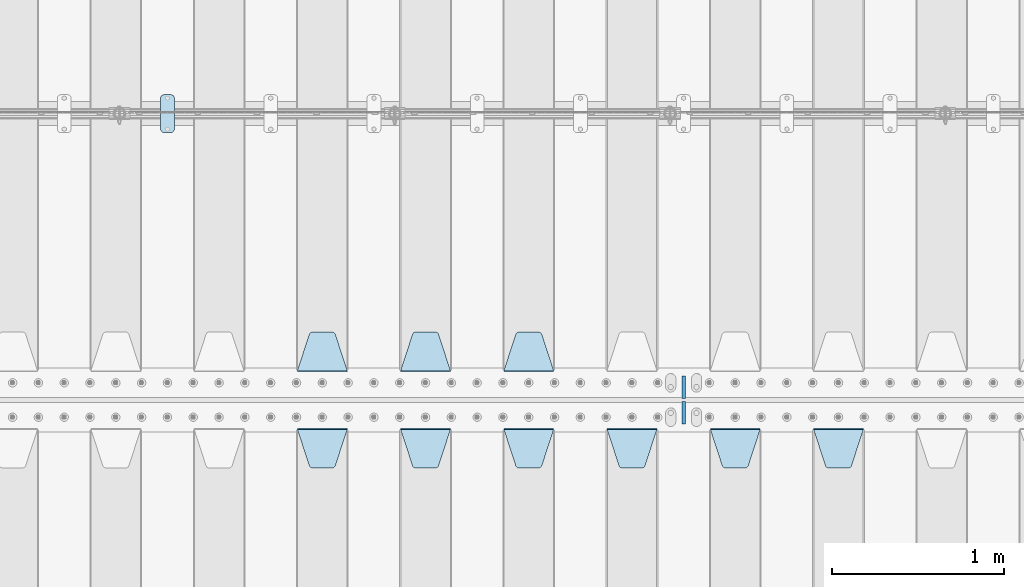
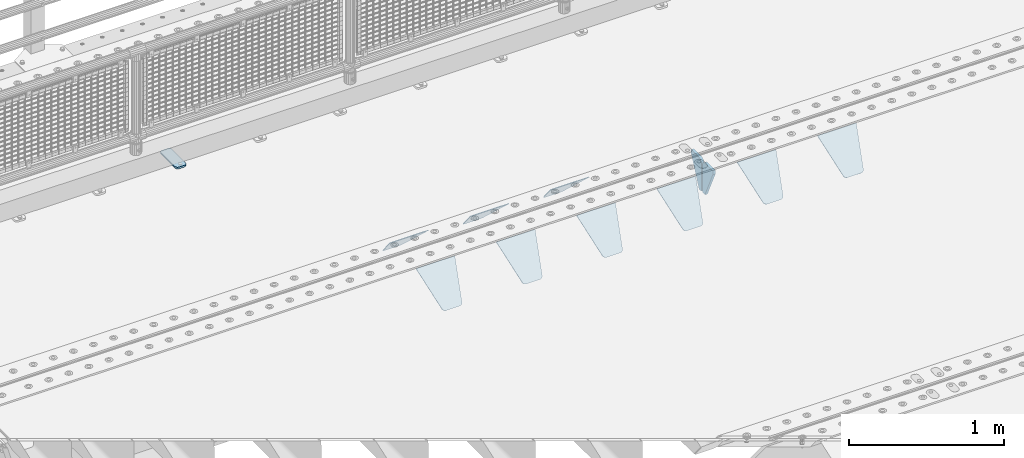
# One storey, part 219 of 257: 12 plates.
"""IFC2X3 building model written with IfcOpenShell, lengths in millimetres."""

from ifc_helpers import new_model, si_unit, frame, origin_with_axes, place, context, subcontext, project, spatial, faceted_brep, material, type_object, element, save


model = new_model("IFC2X3")

# Units and contexts
model_context = context("Model", 3, precision=1e-05, world=origin_with_axes())
body_context = subcontext(model_context, "Body", "Model", "MODEL_VIEW")
ifc_project = project(units=[si_unit("LENGTHUNIT", "METRE", prefix="MILLI"), si_unit("AREAUNIT", "SQUARE_METRE"), si_unit("VOLUMEUNIT", "CUBIC_METRE"), si_unit("MASSUNIT", "GRAM", prefix="KILO"), si_unit("TIMEUNIT", "SECOND"), si_unit("PLANEANGLEUNIT", "RADIAN"), si_unit("SOLIDANGLEUNIT", "STERADIAN"), si_unit("THERMODYNAMICTEMPERATUREUNIT", "DEGREE_CELSIUS"), si_unit("LUMINOUSINTENSITYUNIT", "LUMEN")], contexts=[model_context])

# Site, building, storey
site_placement = place(None, origin_with_axes())
site = spatial("IfcSite", under=ifc_project, at=site_placement, CompositionType="ELEMENT")
building_placement = place(site_placement, origin_with_axes())
building = spatial("IfcBuilding", under=site, at=building_placement, Name="Standard", CompositionType="ELEMENT")
storey_placement = place(building_placement, origin_with_axes())
storey = spatial("IfcBuildingStorey", under=building, at=storey_placement, Name="Undefined", CompositionType="ELEMENT", Elevation=0.0)

# Plates
ifc_material_1 = material(Name="STEEL/S355J2")
plate_type_1 = type_object("IfcPlateType", PredefinedType="NOTDEFINED")
plate_1_placement = place(storey_placement, frame((44910.0, 10774.5, 21.0199999999977), z_axis=(1.0, 0.0, 0.0), x_axis=(0.0, -1.0, 0.0)))
element("IfcPlate", 1, at=plate_1_placement, inside=storey, type_object=plate_type_1, material=ifc_material_1, context=body_context, shape_type="Brep", body=[
    faceted_brep([(0.0, -7.0, 20.0), (0.0, -7.0, 60.0), (0.0, 7.0, 60.0), (0.0, 7.0, 20.0), (0.384294391935327, -7.0, 63.9018064403208), (0.384294391935327, 7.0, 63.9018064403208), (1.52240934977453, -7.0, 67.6536686473046), (1.52240934977453, 7.0, 67.6536686473046), (3.37060775394821, -7.0, 71.1114046603907), (3.37060775394821, 7.0, 71.1114046603907), (5.85786437626848, -7.0, 74.1421356237333), (5.85786437626848, 7.0, 74.1421356237333), (8.88859533960749, -7.0, 76.6293922460536), (8.88859533960749, 7.0, 76.6293922460536), (12.3463313526991, -7.0, 78.4775906502255), (12.3463313526991, 7.0, 78.4775906502255), (16.0981935596774, -7.0, 79.6157056080629), (16.0981935596774, 7.0, 79.6157056080629), (20.0, -7.0, 80.0), (20.0, 7.0, 80.0), (200.0, -7.0, 80.0), (200.0, 7.0, 80.0), (203.901806440323, -7.0, 79.6157056080629), (203.901806440323, 7.0, 79.6157056080629), (207.653668647301, -7.0, 78.4775906502255), (207.653668647301, 7.0, 78.4775906502255), (211.111404660393, -7.0, 76.6293922460536), (211.111404660393, 7.0, 76.6293922460536), (214.142135623732, -7.0, 74.1421356237333), (214.142135623732, 7.0, 74.1421356237333), (216.629392246052, -7.0, 71.1114046603907), (216.629392246052, 7.0, 71.1114046603907), (218.477590650225, -7.0, 67.6536686473046), (218.477590650225, 7.0, 67.6536686473046), (219.615705608065, -7.0, 63.9018064403208), (219.615705608065, 7.0, 63.9018064403208), (220.0, -7.0, 60.0), (220.0, 7.0, 60.0), (220.0, -7.0, 20.0), (220.0, 7.0, 20.0), (219.615705608065, -7.0, 16.0981935596792), (219.615705608065, 7.0, 16.0981935596792), (218.477590650225, -7.0, 12.3463313526954), (218.477590650225, 7.0, 12.3463313526954), (216.629392246052, -7.0, 8.88859533960931), (216.629392246052, 7.0, 8.88859533960931), (214.142135623732, -7.0, 5.85786437626666), (214.142135623732, 7.0, 5.85786437626666), (211.111404660393, -7.0, 3.37060775394639), (211.111404660393, 7.0, 3.37060775394639), (207.653668647301, -7.0, 1.52240934977453), (207.653668647301, 7.0, 1.52240934977453), (203.901806440323, -7.0, 0.384294391937146), (203.901806440323, 7.0, 0.384294391937146), (200.0, -7.0, 0.0), (200.0, 7.0, 0.0), (20.0, -7.0, 0.0), (20.0, 7.0, 0.0), (16.0981935596774, -7.0, 0.384294391937146), (16.0981935596774, 7.0, 0.384294391937146), (12.3463313526991, -7.0, 1.52240934977453), (12.3463313526991, 7.0, 1.52240934977453), (8.88859533960749, -7.0, 3.37060775394639), (8.88859533960749, 7.0, 3.37060775394639), (5.85786437626848, -7.0, 5.85786437626666), (5.85786437626848, 7.0, 5.85786437626666), (3.37060775394821, -7.0, 8.88859533960931), (3.37060775394821, 7.0, 8.88859533960931), (1.52240934977453, -7.0, 12.3463313526954), (1.52240934977453, 7.0, 12.3463313526954), (0.384294391935327, -7.0, 16.0981935596792), (0.384294391935327, 7.0, 16.0981935596792)], [[[0, 1, 2, 3]], [[1, 4, 5, 2]], [[4, 6, 7, 5]], [[6, 8, 9, 7]], [[8, 10, 11, 9]], [[10, 12, 13, 11]], [[12, 14, 15, 13]], [[14, 16, 17, 15]], [[16, 18, 19, 17]], [[18, 20, 21, 19]], [[20, 22, 23, 21]], [[22, 24, 25, 23]], [[24, 26, 27, 25]], [[26, 28, 29, 27]], [[28, 30, 31, 29]], [[30, 32, 33, 31]], [[32, 34, 35, 33]], [[34, 36, 37, 35]], [[36, 38, 39, 37]], [[38, 40, 41, 39]], [[40, 42, 43, 41]], [[42, 44, 45, 43]], [[44, 46, 47, 45]], [[46, 48, 49, 47]], [[48, 50, 51, 49]], [[50, 52, 53, 51]], [[52, 54, 55, 53]], [[54, 56, 57, 55]], [[56, 58, 59, 57]], [[58, 60, 61, 59]], [[60, 62, 63, 61]], [[62, 64, 65, 63]], [[64, 66, 67, 65]], [[66, 68, 69, 67]], [[68, 70, 71, 69]], [[70, 0, 3, 71]], [[5, 7, 9, 11, 13, 15, 17, 19, 21, 23, 25, 27, 29, 31, 33, 35, 37, 39, 41, 43, 45, 47, 49, 51, 53, 55, 57, 59, 61, 63, 65, 67, 69, 71, 3, 2]], [[70, 68, 66, 64, 62, 60, 58, 56, 54, 52, 50, 48, 46, 44, 42, 40, 38, 36, 34, 32, 30, 28, 26, 24, 22, 20, 18, 16, 14, 12, 10, 8, 6, 4, 1, 0]]]),
])
ifc_material_2 = material(Name="STEEL/S355N")
plate_type_2 = type_object("IfcPlateType", PredefinedType="NOTDEFINED")
plate_2_placement = place(storey_placement, frame((48705.0, 8831.76776695594, -1.767766952965), z_axis=(0.0, -0.707106781186548, -0.707106781186547), x_axis=(1.0, 0.0, 0.0)))
element("IfcPlate", 2, at=plate_2_placement, inside=storey, type_object=plate_type_2, material=ifc_material_2, context=body_context, shape_type="Brep", body=[
    faceted_brep([(0.0, -2.5, 0.0), (69.345504679477, -2.50000000000091, 300.17173142483), (69.345504679477, 2.5, 300.171731424831), (0.0, 2.5, 0.0), (70.927406119954, -2.50000000000091, 304.8974424154), (70.927406119954, 2.5, 304.8974424154), (73.3818627772271, -2.50000000000091, 309.234538108527), (73.3818627772271, 2.49999999999909, 309.234538108527), (76.6187032999587, -2.5, 313.023683126103), (76.6187032999587, 2.5, 313.023683126103), (80.5190132705029, -2.5, 316.125672595372), (80.5190132705029, 2.5, 316.125672595371), (84.9395038596849, -2.5, 318.426546230476), (84.9395038596849, 2.5, 318.426546230477), (89.7177759439219, -2.5, 319.841774983275), (89.7177759439219, 2.5, 319.841774983275), (94.6782862926484, -2.5, 320.319366455079), (94.6782862926484, 2.5, 320.319366455079), (195.321713707352, -2.5, 320.319366455079), (195.321713707352, 2.5, 320.319366455079), (200.282224056078, -2.5, 319.841774983275), (200.282224056078, 2.49999999999909, 319.841774983275), (205.060496140315, -2.5, 318.426546230476), (205.060496140315, 2.49999999999909, 318.426546230475), (209.480986729497, -2.5, 316.125672595371), (209.480986729497, 2.5, 316.125672595371), (213.381296700041, -2.50000000000091, 313.023683126102), (213.381296700041, 2.5, 313.023683126103), (216.618137222766, -2.50000000000091, 309.234538108527), (216.618137222766, 2.5, 309.234538108527), (219.072593880039, -2.5, 304.897442415399), (219.072593880039, 2.5, 304.897442415399), (220.654495320523, -2.50000000000091, 300.17173142483), (220.654495320523, 2.5, 300.171731424831), (290.0, -2.50000000000091, 0.0), (290.0, 2.5, 9.09494701772928e-13)], [[[0, 1, 2, 3]], [[1, 4, 5, 2]], [[4, 6, 7, 5]], [[6, 8, 9, 7]], [[8, 10, 11, 9]], [[10, 12, 13, 11]], [[12, 14, 15, 13]], [[14, 16, 17, 15]], [[16, 18, 19, 17]], [[18, 20, 21, 19]], [[20, 22, 23, 21]], [[22, 24, 25, 23]], [[24, 26, 27, 25]], [[26, 28, 29, 27]], [[28, 30, 31, 29]], [[30, 32, 33, 31]], [[32, 34, 35, 33]], [[34, 0, 3, 35]], [[5, 7, 9, 11, 13, 15, 17, 19, 21, 23, 25, 27, 29, 31, 33, 35, 3, 2]], [[34, 32, 30, 28, 26, 24, 22, 20, 18, 16, 14, 12, 10, 8, 6, 4, 1, 0]]]),
])
plate_3_placement = place(storey_placement, frame((48105.0, 8831.76776695594, -1.767766952965), z_axis=(0.0, -0.707106781186548, -0.707106781186547), x_axis=(1.0, 0.0, 0.0)))
element("IfcPlate", 3, at=plate_3_placement, inside=storey, type_object=plate_type_2, material=ifc_material_2, context=body_context, shape_type="Brep", body=[
    faceted_brep([(0.0, -2.5, 0.0), (69.345504679477, -2.50000000000091, 300.17173142483), (69.345504679477, 2.5, 300.171731424831), (0.0, 2.5, 0.0), (70.927406119954, -2.50000000000091, 304.8974424154), (70.927406119954, 2.5, 304.8974424154), (73.3818627772271, -2.50000000000091, 309.234538108527), (73.3818627772271, 2.49999999999909, 309.234538108527), (76.6187032999587, -2.5, 313.023683126103), (76.6187032999587, 2.5, 313.023683126103), (80.5190132705029, -2.5, 316.125672595372), (80.5190132705029, 2.5, 316.125672595371), (84.9395038596849, -2.5, 318.426546230476), (84.9395038596849, 2.5, 318.426546230477), (89.7177759439219, -2.5, 319.841774983275), (89.7177759439219, 2.5, 319.841774983275), (94.6782862926484, -2.5, 320.319366455079), (94.6782862926484, 2.5, 320.319366455079), (195.321713707352, -2.5, 320.319366455079), (195.321713707352, 2.5, 320.319366455079), (200.282224056078, -2.5, 319.841774983275), (200.282224056078, 2.49999999999909, 319.841774983275), (205.060496140315, -2.5, 318.426546230476), (205.060496140315, 2.49999999999909, 318.426546230475), (209.480986729497, -2.5, 316.125672595371), (209.480986729497, 2.5, 316.125672595371), (213.381296700041, -2.50000000000091, 313.023683126102), (213.381296700041, 2.5, 313.023683126103), (216.618137222766, -2.50000000000091, 309.234538108527), (216.618137222766, 2.5, 309.234538108527), (219.072593880039, -2.5, 304.897442415399), (219.072593880039, 2.5, 304.897442415399), (220.654495320523, -2.50000000000091, 300.17173142483), (220.654495320523, 2.5, 300.171731424831), (290.0, -2.50000000000091, 0.0), (290.0, 2.5, 9.09494701772928e-13)], [[[0, 1, 2, 3]], [[1, 4, 5, 2]], [[4, 6, 7, 5]], [[6, 8, 9, 7]], [[8, 10, 11, 9]], [[10, 12, 13, 11]], [[12, 14, 15, 13]], [[14, 16, 17, 15]], [[16, 18, 19, 17]], [[18, 20, 21, 19]], [[20, 22, 23, 21]], [[22, 24, 25, 23]], [[24, 26, 27, 25]], [[26, 28, 29, 27]], [[28, 30, 31, 29]], [[30, 32, 33, 31]], [[32, 34, 35, 33]], [[34, 0, 3, 35]], [[5, 7, 9, 11, 13, 15, 17, 19, 21, 23, 25, 27, 29, 31, 33, 35, 3, 2]], [[34, 32, 30, 28, 26, 24, 22, 20, 18, 16, 14, 12, 10, 8, 6, 4, 1, 0]]]),
])
plate_4_placement = place(storey_placement, frame((47505.0, 8831.76776695594, -1.767766952965), z_axis=(0.0, -0.707106781186548, -0.707106781186547), x_axis=(1.0, 0.0, 0.0)))
element("IfcPlate", 4, at=plate_4_placement, inside=storey, type_object=plate_type_2, material=ifc_material_2, context=body_context, shape_type="Brep", body=[
    faceted_brep([(0.0, -2.5, 0.0), (69.345504679477, -2.50000000000091, 300.17173142483), (69.345504679477, 2.5, 300.171731424831), (0.0, 2.5, 0.0), (70.927406119954, -2.50000000000091, 304.8974424154), (70.927406119954, 2.5, 304.8974424154), (73.3818627772271, -2.50000000000091, 309.234538108527), (73.3818627772271, 2.49999999999909, 309.234538108527), (76.6187032999587, -2.5, 313.023683126103), (76.6187032999587, 2.5, 313.023683126103), (80.5190132705029, -2.5, 316.125672595372), (80.5190132705029, 2.5, 316.125672595371), (84.9395038596849, -2.5, 318.426546230476), (84.9395038596849, 2.5, 318.426546230477), (89.7177759439219, -2.5, 319.841774983275), (89.7177759439219, 2.5, 319.841774983275), (94.6782862926484, -2.5, 320.319366455079), (94.6782862926484, 2.5, 320.319366455079), (195.321713707352, -2.5, 320.319366455079), (195.321713707352, 2.5, 320.319366455079), (200.282224056078, -2.5, 319.841774983275), (200.282224056078, 2.49999999999909, 319.841774983275), (205.060496140315, -2.5, 318.426546230476), (205.060496140315, 2.49999999999909, 318.426546230475), (209.480986729497, -2.5, 316.125672595371), (209.480986729497, 2.5, 316.125672595371), (213.381296700041, -2.50000000000091, 313.023683126102), (213.381296700041, 2.5, 313.023683126103), (216.618137222766, -2.50000000000091, 309.234538108527), (216.618137222766, 2.5, 309.234538108527), (219.072593880039, -2.5, 304.897442415399), (219.072593880039, 2.5, 304.897442415399), (220.654495320523, -2.50000000000091, 300.17173142483), (220.654495320523, 2.5, 300.171731424831), (290.0, -2.50000000000091, 0.0), (290.0, 2.5, 9.09494701772928e-13)], [[[0, 1, 2, 3]], [[1, 4, 5, 2]], [[4, 6, 7, 5]], [[6, 8, 9, 7]], [[8, 10, 11, 9]], [[10, 12, 13, 11]], [[12, 14, 15, 13]], [[14, 16, 17, 15]], [[16, 18, 19, 17]], [[18, 20, 21, 19]], [[20, 22, 23, 21]], [[22, 24, 25, 23]], [[24, 26, 27, 25]], [[26, 28, 29, 27]], [[28, 30, 31, 29]], [[30, 32, 33, 31]], [[32, 34, 35, 33]], [[34, 0, 3, 35]], [[5, 7, 9, 11, 13, 15, 17, 19, 21, 23, 25, 27, 29, 31, 33, 35, 3, 2]], [[34, 32, 30, 28, 26, 24, 22, 20, 18, 16, 14, 12, 10, 8, 6, 4, 1, 0]]]),
])
plate_5_placement = place(storey_placement, frame((46905.0, 8831.76776695594, -1.767766952965), z_axis=(0.0, -0.707106781186548, -0.707106781186547), x_axis=(1.0, 0.0, 0.0)))
element("IfcPlate", 5, at=plate_5_placement, inside=storey, type_object=plate_type_2, material=ifc_material_2, context=body_context, shape_type="Brep", body=[
    faceted_brep([(0.0, -2.5, 0.0), (69.345504679477, -2.50000000000091, 300.17173142483), (69.345504679477, 2.5, 300.171731424831), (0.0, 2.5, 0.0), (70.927406119954, -2.50000000000091, 304.8974424154), (70.927406119954, 2.5, 304.8974424154), (73.3818627772271, -2.50000000000091, 309.234538108527), (73.3818627772271, 2.49999999999909, 309.234538108527), (76.6187032999587, -2.5, 313.023683126103), (76.6187032999587, 2.5, 313.023683126103), (80.5190132705029, -2.5, 316.125672595372), (80.5190132705029, 2.5, 316.125672595371), (84.9395038596849, -2.5, 318.426546230476), (84.9395038596849, 2.5, 318.426546230477), (89.7177759439219, -2.5, 319.841774983275), (89.7177759439219, 2.5, 319.841774983275), (94.6782862926484, -2.5, 320.319366455079), (94.6782862926484, 2.5, 320.319366455079), (195.321713707352, -2.5, 320.319366455079), (195.321713707352, 2.5, 320.319366455079), (200.282224056078, -2.5, 319.841774983275), (200.282224056078, 2.49999999999909, 319.841774983275), (205.060496140315, -2.5, 318.426546230476), (205.060496140315, 2.49999999999909, 318.426546230475), (209.480986729497, -2.5, 316.125672595371), (209.480986729497, 2.5, 316.125672595371), (213.381296700041, -2.50000000000091, 313.023683126102), (213.381296700041, 2.5, 313.023683126103), (216.618137222766, -2.50000000000091, 309.234538108527), (216.618137222766, 2.5, 309.234538108527), (219.072593880039, -2.5, 304.897442415399), (219.072593880039, 2.5, 304.897442415399), (220.654495320523, -2.50000000000091, 300.17173142483), (220.654495320523, 2.5, 300.171731424831), (290.0, -2.50000000000091, 0.0), (290.0, 2.5, 9.09494701772928e-13)], [[[0, 1, 2, 3]], [[1, 4, 5, 2]], [[4, 6, 7, 5]], [[6, 8, 9, 7]], [[8, 10, 11, 9]], [[10, 12, 13, 11]], [[12, 14, 15, 13]], [[14, 16, 17, 15]], [[16, 18, 19, 17]], [[18, 20, 21, 19]], [[20, 22, 23, 21]], [[22, 24, 25, 23]], [[24, 26, 27, 25]], [[26, 28, 29, 27]], [[28, 30, 31, 29]], [[30, 32, 33, 31]], [[32, 34, 35, 33]], [[34, 0, 3, 35]], [[5, 7, 9, 11, 13, 15, 17, 19, 21, 23, 25, 27, 29, 31, 33, 35, 3, 2]], [[34, 32, 30, 28, 26, 24, 22, 20, 18, 16, 14, 12, 10, 8, 6, 4, 1, 0]]]),
])
plate_6_placement = place(storey_placement, frame((46305.0, 8831.76776695594, -1.767766952965), z_axis=(0.0, -0.707106781186548, -0.707106781186547), x_axis=(1.0, 0.0, 0.0)))
element("IfcPlate", 6, at=plate_6_placement, inside=storey, type_object=plate_type_2, material=ifc_material_2, context=body_context, shape_type="Brep", body=[
    faceted_brep([(0.0, -2.5, 0.0), (69.345504679477, -2.50000000000091, 300.17173142483), (69.345504679477, 2.5, 300.171731424831), (0.0, 2.5, 0.0), (70.927406119954, -2.50000000000091, 304.8974424154), (70.927406119954, 2.5, 304.8974424154), (73.3818627772271, -2.50000000000091, 309.234538108527), (73.3818627772271, 2.49999999999909, 309.234538108527), (76.6187032999587, -2.5, 313.023683126103), (76.6187032999587, 2.5, 313.023683126103), (80.5190132705029, -2.5, 316.125672595372), (80.5190132705029, 2.5, 316.125672595371), (84.9395038596849, -2.5, 318.426546230476), (84.9395038596849, 2.5, 318.426546230477), (89.7177759439219, -2.5, 319.841774983275), (89.7177759439219, 2.5, 319.841774983275), (94.6782862926484, -2.5, 320.319366455079), (94.6782862926484, 2.5, 320.319366455079), (195.321713707352, -2.5, 320.319366455079), (195.321713707352, 2.5, 320.319366455079), (200.282224056078, -2.5, 319.841774983275), (200.282224056078, 2.49999999999909, 319.841774983275), (205.060496140315, -2.5, 318.426546230476), (205.060496140315, 2.49999999999909, 318.426546230475), (209.480986729497, -2.5, 316.125672595371), (209.480986729497, 2.5, 316.125672595371), (213.381296700041, -2.50000000000091, 313.023683126102), (213.381296700041, 2.5, 313.023683126103), (216.618137222766, -2.50000000000091, 309.234538108527), (216.618137222766, 2.5, 309.234538108527), (219.072593880039, -2.5, 304.897442415399), (219.072593880039, 2.5, 304.897442415399), (220.654495320523, -2.50000000000091, 300.17173142483), (220.654495320523, 2.5, 300.171731424831), (290.0, -2.50000000000091, 0.0), (290.0, 2.5, 9.09494701772928e-13)], [[[0, 1, 2, 3]], [[1, 4, 5, 2]], [[4, 6, 7, 5]], [[6, 8, 9, 7]], [[8, 10, 11, 9]], [[10, 12, 13, 11]], [[12, 14, 15, 13]], [[14, 16, 17, 15]], [[16, 18, 19, 17]], [[18, 20, 21, 19]], [[20, 22, 23, 21]], [[22, 24, 25, 23]], [[24, 26, 27, 25]], [[26, 28, 29, 27]], [[28, 30, 31, 29]], [[30, 32, 33, 31]], [[32, 34, 35, 33]], [[34, 0, 3, 35]], [[5, 7, 9, 11, 13, 15, 17, 19, 21, 23, 25, 27, 29, 31, 33, 35, 3, 2]], [[34, 32, 30, 28, 26, 24, 22, 20, 18, 16, 14, 12, 10, 8, 6, 4, 1, 0]]]),
])
plate_7_placement = place(storey_placement, frame((45705.0, 8831.76776695594, -1.767766952965), z_axis=(0.0, -0.707106781186548, -0.707106781186547), x_axis=(1.0, 0.0, 0.0)))
element("IfcPlate", 7, at=plate_7_placement, inside=storey, type_object=plate_type_2, material=ifc_material_2, context=body_context, shape_type="Brep", body=[
    faceted_brep([(0.0, -2.5, 0.0), (69.345504679477, -2.50000000000091, 300.17173142483), (69.345504679477, 2.5, 300.171731424831), (0.0, 2.5, 0.0), (70.927406119954, -2.50000000000091, 304.8974424154), (70.927406119954, 2.5, 304.8974424154), (73.3818627772271, -2.50000000000091, 309.234538108527), (73.3818627772271, 2.49999999999909, 309.234538108527), (76.6187032999587, -2.5, 313.023683126103), (76.6187032999587, 2.5, 313.023683126103), (80.5190132705029, -2.5, 316.125672595372), (80.5190132705029, 2.5, 316.125672595371), (84.9395038596849, -2.5, 318.426546230476), (84.9395038596849, 2.5, 318.426546230477), (89.7177759439219, -2.5, 319.841774983275), (89.7177759439219, 2.5, 319.841774983275), (94.6782862926484, -2.5, 320.319366455079), (94.6782862926484, 2.5, 320.319366455079), (195.321713707352, -2.5, 320.319366455079), (195.321713707352, 2.5, 320.319366455079), (200.282224056078, -2.5, 319.841774983275), (200.282224056078, 2.49999999999909, 319.841774983275), (205.060496140315, -2.5, 318.426546230476), (205.060496140315, 2.49999999999909, 318.426546230475), (209.480986729497, -2.5, 316.125672595371), (209.480986729497, 2.5, 316.125672595371), (213.381296700041, -2.50000000000091, 313.023683126102), (213.381296700041, 2.5, 313.023683126103), (216.618137222766, -2.50000000000091, 309.234538108527), (216.618137222766, 2.5, 309.234538108527), (219.072593880039, -2.5, 304.897442415399), (219.072593880039, 2.5, 304.897442415399), (220.654495320523, -2.50000000000091, 300.17173142483), (220.654495320523, 2.5, 300.171731424831), (290.0, -2.50000000000091, 0.0), (290.0, 2.5, 9.09494701772928e-13)], [[[0, 1, 2, 3]], [[1, 4, 5, 2]], [[4, 6, 7, 5]], [[6, 8, 9, 7]], [[8, 10, 11, 9]], [[10, 12, 13, 11]], [[12, 14, 15, 13]], [[14, 16, 17, 15]], [[16, 18, 19, 17]], [[18, 20, 21, 19]], [[20, 22, 23, 21]], [[22, 24, 25, 23]], [[24, 26, 27, 25]], [[26, 28, 29, 27]], [[28, 30, 31, 29]], [[30, 32, 33, 31]], [[32, 34, 35, 33]], [[34, 0, 3, 35]], [[5, 7, 9, 11, 13, 15, 17, 19, 21, 23, 25, 27, 29, 31, 33, 35, 3, 2]], [[34, 32, 30, 28, 26, 24, 22, 20, 18, 16, 14, 12, 10, 8, 6, 4, 1, 0]]]),
])
plate_8_placement = place(storey_placement, frame((47195.0, 9168.23223304703, -1.76776695296758), z_axis=(0.0, 0.707106781186547, -0.707106781186548), x_axis=(-1.0, 0.0, 0.0)))
element("IfcPlate", 8, at=plate_8_placement, inside=storey, type_object=plate_type_2, material=ifc_material_2, context=body_context, shape_type="Brep", body=[
    faceted_brep([(0.0, -2.5, 0.0), (69.345504679477, -2.50000000000091, 300.17173142483), (69.345504679477, 2.5, 300.171731424831), (0.0, 2.5, 0.0), (70.927406119954, -2.50000000000091, 304.8974424154), (70.927406119954, 2.5, 304.8974424154), (73.3818627772271, -2.50000000000091, 309.234538108527), (73.3818627772271, 2.49999999999909, 309.234538108527), (76.6187032999587, -2.5, 313.023683126103), (76.6187032999587, 2.5, 313.023683126103), (80.5190132705029, -2.5, 316.125672595372), (80.5190132705029, 2.5, 316.125672595371), (84.9395038596849, -2.5, 318.426546230476), (84.9395038596849, 2.5, 318.426546230477), (89.7177759439219, -2.5, 319.841774983275), (89.7177759439219, 2.5, 319.841774983275), (94.6782862926484, -2.5, 320.319366455079), (94.6782862926484, 2.5, 320.319366455079), (195.321713707352, -2.5, 320.319366455079), (195.321713707352, 2.5, 320.319366455079), (200.282224056078, -2.5, 319.841774983275), (200.282224056078, 2.49999999999909, 319.841774983275), (205.060496140315, -2.5, 318.426546230476), (205.060496140315, 2.49999999999909, 318.426546230475), (209.480986729497, -2.5, 316.125672595371), (209.480986729497, 2.5, 316.125672595371), (213.381296700041, -2.50000000000091, 313.023683126102), (213.381296700041, 2.5, 313.023683126103), (216.618137222766, -2.50000000000091, 309.234538108527), (216.618137222766, 2.5, 309.234538108527), (219.072593880039, -2.5, 304.897442415399), (219.072593880039, 2.5, 304.897442415399), (220.654495320523, -2.50000000000091, 300.17173142483), (220.654495320523, 2.5, 300.171731424831), (290.0, -2.50000000000091, 0.0), (290.0, 2.5, 9.09494701772928e-13)], [[[0, 1, 2, 3]], [[1, 4, 5, 2]], [[4, 6, 7, 5]], [[6, 8, 9, 7]], [[8, 10, 11, 9]], [[10, 12, 13, 11]], [[12, 14, 15, 13]], [[14, 16, 17, 15]], [[16, 18, 19, 17]], [[18, 20, 21, 19]], [[20, 22, 23, 21]], [[22, 24, 25, 23]], [[24, 26, 27, 25]], [[26, 28, 29, 27]], [[28, 30, 31, 29]], [[30, 32, 33, 31]], [[32, 34, 35, 33]], [[34, 0, 3, 35]], [[5, 7, 9, 11, 13, 15, 17, 19, 21, 23, 25, 27, 29, 31, 33, 35, 3, 2]], [[34, 32, 30, 28, 26, 24, 22, 20, 18, 16, 14, 12, 10, 8, 6, 4, 1, 0]]]),
])
plate_9_placement = place(storey_placement, frame((46595.0, 9168.23223304703, -1.76776695296758), z_axis=(0.0, 0.707106781186547, -0.707106781186548), x_axis=(-1.0, 0.0, 0.0)))
element("IfcPlate", 9, at=plate_9_placement, inside=storey, type_object=plate_type_2, material=ifc_material_2, context=body_context, shape_type="Brep", body=[
    faceted_brep([(0.0, -2.5, 0.0), (69.345504679477, -2.50000000000091, 300.17173142483), (69.345504679477, 2.5, 300.171731424831), (0.0, 2.5, 0.0), (70.927406119954, -2.50000000000091, 304.8974424154), (70.927406119954, 2.5, 304.8974424154), (73.3818627772271, -2.50000000000091, 309.234538108527), (73.3818627772271, 2.49999999999909, 309.234538108527), (76.6187032999587, -2.5, 313.023683126103), (76.6187032999587, 2.5, 313.023683126103), (80.5190132705029, -2.5, 316.125672595372), (80.5190132705029, 2.5, 316.125672595371), (84.9395038596849, -2.5, 318.426546230476), (84.9395038596849, 2.5, 318.426546230477), (89.7177759439219, -2.5, 319.841774983275), (89.7177759439219, 2.5, 319.841774983275), (94.6782862926484, -2.5, 320.319366455079), (94.6782862926484, 2.5, 320.319366455079), (195.321713707352, -2.5, 320.319366455079), (195.321713707352, 2.5, 320.319366455079), (200.282224056078, -2.5, 319.841774983275), (200.282224056078, 2.49999999999909, 319.841774983275), (205.060496140315, -2.5, 318.426546230476), (205.060496140315, 2.49999999999909, 318.426546230475), (209.480986729497, -2.5, 316.125672595371), (209.480986729497, 2.5, 316.125672595371), (213.381296700041, -2.50000000000091, 313.023683126102), (213.381296700041, 2.5, 313.023683126103), (216.618137222766, -2.50000000000091, 309.234538108527), (216.618137222766, 2.5, 309.234538108527), (219.072593880039, -2.5, 304.897442415399), (219.072593880039, 2.5, 304.897442415399), (220.654495320523, -2.50000000000091, 300.17173142483), (220.654495320523, 2.5, 300.171731424831), (290.0, -2.50000000000091, 0.0), (290.0, 2.5, 9.09494701772928e-13)], [[[0, 1, 2, 3]], [[1, 4, 5, 2]], [[4, 6, 7, 5]], [[6, 8, 9, 7]], [[8, 10, 11, 9]], [[10, 12, 13, 11]], [[12, 14, 15, 13]], [[14, 16, 17, 15]], [[16, 18, 19, 17]], [[18, 20, 21, 19]], [[20, 22, 23, 21]], [[22, 24, 25, 23]], [[24, 26, 27, 25]], [[26, 28, 29, 27]], [[28, 30, 31, 29]], [[30, 32, 33, 31]], [[32, 34, 35, 33]], [[34, 0, 3, 35]], [[5, 7, 9, 11, 13, 15, 17, 19, 21, 23, 25, 27, 29, 31, 33, 35, 3, 2]], [[34, 32, 30, 28, 26, 24, 22, 20, 18, 16, 14, 12, 10, 8, 6, 4, 1, 0]]]),
])
plate_10_placement = place(storey_placement, frame((45995.0, 9168.23223304703, -1.76776695296758), z_axis=(0.0, 0.707106781186547, -0.707106781186548), x_axis=(-1.0, 0.0, 0.0)))
element("IfcPlate", 10, at=plate_10_placement, inside=storey, type_object=plate_type_2, material=ifc_material_2, context=body_context, shape_type="Brep", body=[
    faceted_brep([(0.0, -2.5, 0.0), (69.345504679477, -2.50000000000091, 300.17173142483), (69.345504679477, 2.5, 300.171731424831), (0.0, 2.5, 0.0), (70.927406119954, -2.50000000000091, 304.8974424154), (70.927406119954, 2.5, 304.8974424154), (73.3818627772271, -2.50000000000091, 309.234538108527), (73.3818627772271, 2.49999999999909, 309.234538108527), (76.6187032999587, -2.5, 313.023683126103), (76.6187032999587, 2.5, 313.023683126103), (80.5190132705029, -2.5, 316.125672595372), (80.5190132705029, 2.5, 316.125672595371), (84.9395038596849, -2.5, 318.426546230476), (84.9395038596849, 2.5, 318.426546230477), (89.7177759439219, -2.5, 319.841774983275), (89.7177759439219, 2.5, 319.841774983275), (94.6782862926484, -2.5, 320.319366455079), (94.6782862926484, 2.5, 320.319366455079), (195.321713707352, -2.5, 320.319366455079), (195.321713707352, 2.5, 320.319366455079), (200.282224056078, -2.5, 319.841774983275), (200.282224056078, 2.49999999999909, 319.841774983275), (205.060496140315, -2.5, 318.426546230476), (205.060496140315, 2.49999999999909, 318.426546230475), (209.480986729497, -2.5, 316.125672595371), (209.480986729497, 2.5, 316.125672595371), (213.381296700041, -2.50000000000091, 313.023683126102), (213.381296700041, 2.5, 313.023683126103), (216.618137222766, -2.50000000000091, 309.234538108527), (216.618137222766, 2.5, 309.234538108527), (219.072593880039, -2.5, 304.897442415399), (219.072593880039, 2.5, 304.897442415399), (220.654495320523, -2.50000000000091, 300.17173142483), (220.654495320523, 2.5, 300.171731424831), (290.0, -2.50000000000091, 0.0), (290.0, 2.5, 9.09494701772928e-13)], [[[0, 1, 2, 3]], [[1, 4, 5, 2]], [[4, 6, 7, 5]], [[6, 8, 9, 7]], [[8, 10, 11, 9]], [[10, 12, 13, 11]], [[12, 14, 15, 13]], [[14, 16, 17, 15]], [[16, 18, 19, 17]], [[18, 20, 21, 19]], [[20, 22, 23, 21]], [[22, 24, 25, 23]], [[24, 26, 27, 25]], [[26, 28, 29, 27]], [[28, 30, 31, 29]], [[30, 32, 33, 31]], [[32, 34, 35, 33]], [[34, 0, 3, 35]], [[5, 7, 9, 11, 13, 15, 17, 19, 21, 23, 25, 27, 29, 31, 33, 35, 3, 2]], [[34, 32, 30, 28, 26, 24, 22, 20, 18, 16, 14, 12, 10, 8, 6, 4, 1, 0]]]),
])
plate_type_3 = type_object("IfcPlateType", PredefinedType="NOTDEFINED")
for number, where, z_axis, x_axis in (
    (11, (47950.0, 9140.0, -30.0), (0.0, 0.0, -1.0), (0.0, -1.0, 0.0)),
    (12, (47950.0, 8860.0, -30.0), (0.0, 0.0, -1.0), (0.0, 1.0, 0.0)),
):
    element("IfcPlate", number, at=place(storey_placement, frame(where, z_axis=z_axis, x_axis=x_axis)), inside=storey, type_object=plate_type_3, material=ifc_material_2, context=body_context, shape_type="Brep", body=[
        faceted_brep([(0.0, -10.0, 0.0), (0.0, -10.0, 30.0), (0.0, 10.0, 30.0), (0.0, 10.0, 0.0), (102.0, -10.0, 250.0), (102.0, 10.0, 250.0), (132.0, -10.0, 250.0), (132.0, 10.0, 250.0), (132.0, -10.0, 30.0), (132.0, 10.0, 30.0), (131.544232590366, -10.0, 24.790554669992), (131.544232590366, 10.0, 24.790554669992), (130.190778623577, -10.0, 19.7393957002299), (130.190778623577, 10.0, 19.7393957002299), (127.980762113533, -10.0, 15.0), (127.980762113533, 10.0, 15.0), (124.981333293569, -10.0, 10.7163717094038), (124.981333293569, 10.0, 10.7163717094038), (121.283628290596, -10.0, 7.01866670643062), (121.283628290596, 10.0, 7.01866670643062), (117.0, -10.0, 4.01923788646684), (117.0, 10.0, 4.01923788646684), (112.26060429977, -10.0, 1.80922137642278), (112.26060429977, 10.0, 1.80922137642278), (107.209445330008, -10.0, 0.455767409633722), (107.209445330008, 10.0, 0.455767409633722), (102.0, -10.0, 0.0), (102.0, 10.0, 0.0)], [[[0, 1, 2, 3]], [[1, 4, 5, 2]], [[4, 6, 7, 5]], [[6, 8, 9, 7]], [[8, 10, 11, 9]], [[10, 12, 13, 11]], [[12, 14, 15, 13]], [[14, 16, 17, 15]], [[16, 18, 19, 17]], [[18, 20, 21, 19]], [[20, 22, 23, 21]], [[22, 24, 25, 23]], [[24, 26, 27, 25]], [[26, 0, 3, 27]], [[5, 7, 9, 11, 13, 15, 17, 19, 21, 23, 25, 27, 3, 2]], [[26, 24, 22, 20, 18, 16, 14, 12, 10, 8, 6, 4, 1, 0]]]),
    ])

save(model, "model.ifc")
